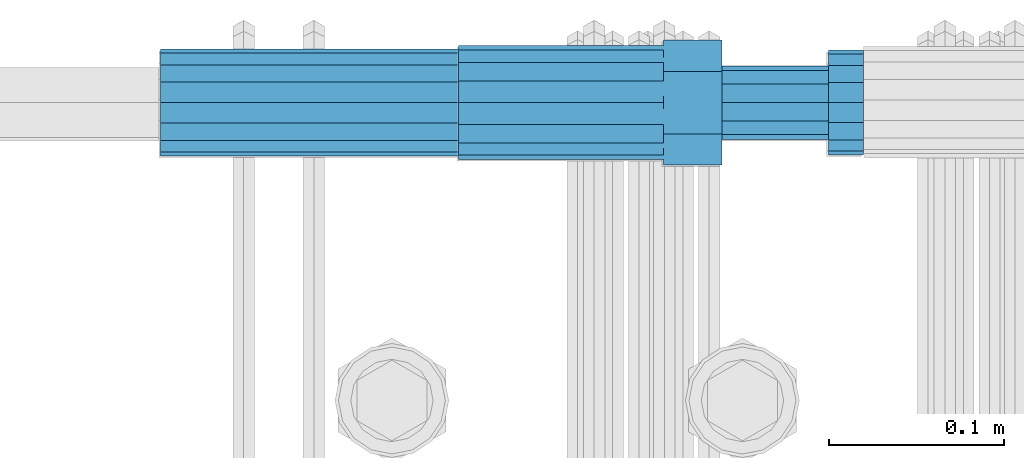
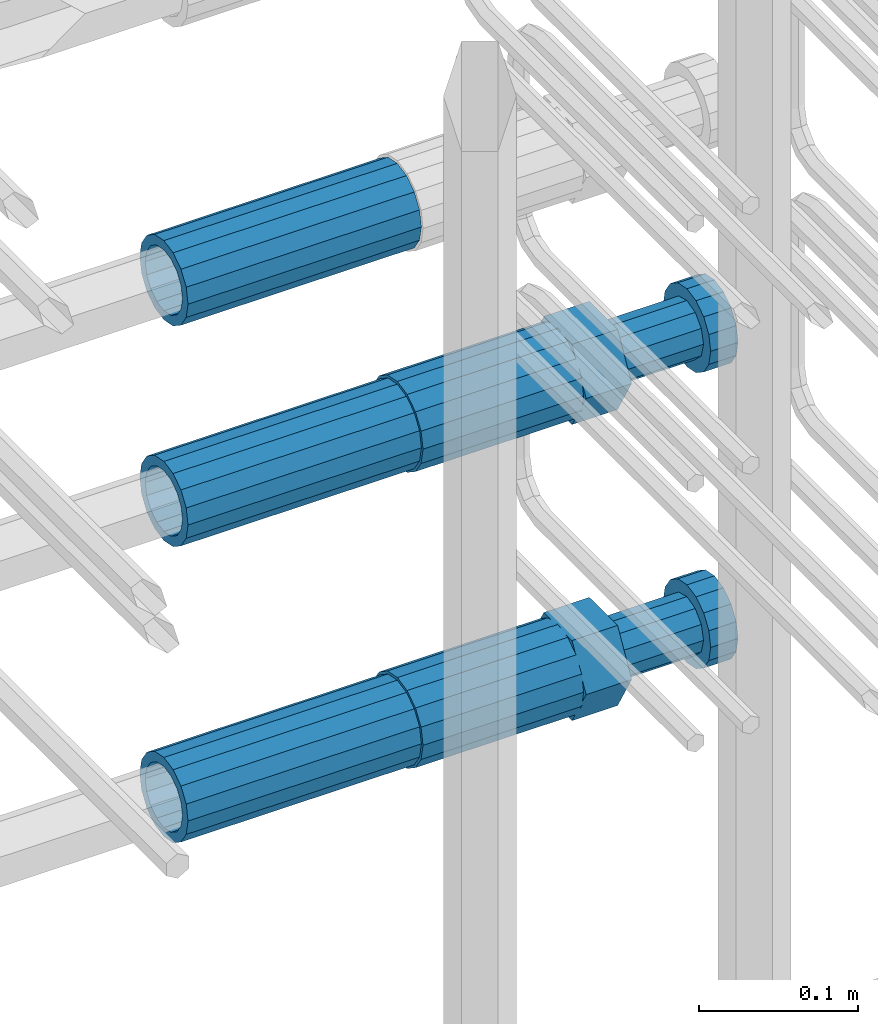
# One storey, part 51 of 177: 5 beams.
"""IFC2X3 building model written with IfcOpenShell, lengths in millimetres."""

from ifc_helpers import new_model, si_unit, frame, origin_with_axes, place, context, subcontext, project, spatial, faceted_brep, material, type_object, element, save


model = new_model("IFC2X3")

# Units and contexts
model_context_1 = context("Model", 3, precision=1e-05, world=origin_with_axes())
model_context_2 = context("Model", 3, precision=1e-05, world=origin_with_axes())
body_context = subcontext(model_context_2, "Body", "Model", "MODEL_VIEW")
ifc_project = project(units=[si_unit("LENGTHUNIT", "METRE", prefix="MILLI"), si_unit("AREAUNIT", "SQUARE_METRE"), si_unit("VOLUMEUNIT", "CUBIC_METRE"), si_unit("MASSUNIT", "GRAM", prefix="KILO"), si_unit("TIMEUNIT", "SECOND"), si_unit("PLANEANGLEUNIT", "RADIAN"), si_unit("SOLIDANGLEUNIT", "STERADIAN"), si_unit("THERMODYNAMICTEMPERATUREUNIT", "DEGREE_CELSIUS"), si_unit("LUMINOUSINTENSITYUNIT", "LUMEN")], contexts=[model_context_1])

# Site, building, storey
site_placement = place(None, origin_with_axes())
site = spatial("IfcSite", under=ifc_project, at=site_placement, CompositionType="ELEMENT")
building_placement = place(site_placement, origin_with_axes())
building = spatial("IfcBuilding", under=site, at=building_placement, Name="Undefined", CompositionType="ELEMENT")
storey_placement = place(building_placement, origin_with_axes())
storey = spatial("IfcBuildingStorey", under=building, at=storey_placement, Name="Undefined", CompositionType="ELEMENT", Elevation=0.0)

# Beams
ifc_material = material(Name="STEEL/S275")
beam_type_1 = type_object("IfcBeamType", PredefinedType="NOTDEFINED")
beam_1_placement = place(storey_placement, frame((2031449.01847313, 6206398.98588031, 20184.6868004325), z_axis=(0.0, 0.0, -1.0), x_axis=(1.0, 0.0, 0.0)))
element("IfcBeam", 1, at=beam_1_placement, inside=storey, type_object=beam_type_1, material=ifc_material, Name="AG40N", context=body_context, shape_type="Brep", body=[
    faceted_brep([(0.0, -23.5000000001164, -9.31322574615479e-10), (0.0, -21.7111690140155, 8.99306066054851), (170.0, -21.7111690140155, 8.99306066054851), (170.0, -23.5, 0.0), (0.0, -16.6170093578839, 16.6170093575493), (170.0, -16.6170093578839, 16.6170093575493), (0.0, -8.99306066057943, 21.7111690137535), (170.0, -8.99306066057943, 21.7111690137535), (0.0, 1.16415321826935e-10, 23.5), (170.0, 0.0, 23.5), (0.0, 8.99306066057943, 21.7111690137535), (170.0, 8.99306066057943, 21.7111690137535), (0.0, 16.6170093578839, 16.6170093575493), (170.0, 16.6170093578839, 16.6170093575493), (0.0, 21.7111690140155, 8.99306066054851), (170.0, 21.7111690140155, 8.99306066054851), (0.0, 23.5000000001164, -9.31322574615479e-10), (170.0, 23.5, 0.0), (0.0, 21.7111690140155, -8.99306066054851), (170.0, 21.7111690140155, -8.99306066054851), (0.0, 16.6170093578839, -16.6170093575493), (170.0, 16.6170093578839, -16.6170093575493), (0.0, 8.99306066057943, -21.7111690137535), (170.0, 8.99306066057943, -21.7111690137535), (0.0, 1.16415321826935e-10, -23.5000000009313), (170.0, 0.0, -23.5), (0.0, -8.99306066057943, -21.7111690137535), (170.0, -8.99306066057943, -21.7111690137535), (0.0, -16.6170093578839, -16.6170093575493), (170.0, -16.6170093578839, -16.6170093575493), (0.0, -21.7111690140155, -8.99306066054851), (170.0, -21.7111690140155, -8.99306066054851), (0.0, -30.5, 0.0), (0.0, -28.1783257415937, -11.6718446873128), (170.0, -28.1783257415937, -11.6718446873128), (170.0, -30.5, 0.0), (0.0, -21.5667568261888, -21.5667568258941), (170.0, -21.5667568261888, -21.5667568258941), (0.0, -11.6718446871346, -28.1783257415518), (170.0, -11.6718446871346, -28.1783257415518), (0.0, 0.0, -30.5), (170.0, 0.0, -30.5), (0.0, 11.6718446871346, -28.1783257415518), (170.0, 11.6718446871346, -28.1783257415518), (0.0, 21.5667568261888, -21.5667568258941), (170.0, 21.5667568261888, -21.5667568258941), (0.0, 28.1783257415937, -11.6718446873128), (170.0, 28.1783257415937, -11.6718446873128), (0.0, 30.5, 0.0), (170.0, 30.5, 0.0), (0.0, 28.1783257415937, 11.6718446873128), (170.0, 28.1783257415937, 11.6718446873128), (0.0, 21.5667568261888, 21.5667568258941), (170.0, 21.5667568261888, 21.5667568258941), (0.0, 11.6718446871346, 28.1783257415518), (170.0, 11.6718446871346, 28.1783257415518), (0.0, 0.0, 30.5), (170.0, 0.0, 30.5), (0.0, -11.6718446871346, 28.1783257415518), (170.0, -11.6718446871346, 28.1783257415518), (0.0, -21.5667568261888, 21.5667568258941), (170.0, -21.5667568261888, 21.5667568258941), (0.0, -28.1783257415937, 11.6718446873128), (170.0, -28.1783257415937, 11.6718446873128)], [[[0, 1, 2, 3]], [[1, 4, 5, 2]], [[4, 6, 7, 5]], [[6, 8, 9, 7]], [[8, 10, 11, 9]], [[10, 12, 13, 11]], [[12, 14, 15, 13]], [[14, 16, 17, 15]], [[16, 18, 19, 17]], [[18, 20, 21, 19]], [[20, 22, 23, 21]], [[22, 24, 25, 23]], [[24, 26, 27, 25]], [[26, 28, 29, 27]], [[28, 30, 31, 29]], [[30, 0, 3, 31]], [[32, 33, 34, 35]], [[33, 36, 37, 34]], [[36, 38, 39, 37]], [[38, 40, 41, 39]], [[40, 42, 43, 41]], [[42, 44, 45, 43]], [[44, 46, 47, 45]], [[46, 48, 49, 47]], [[48, 50, 51, 49]], [[50, 52, 53, 51]], [[52, 54, 55, 53]], [[54, 56, 57, 55]], [[56, 58, 59, 57]], [[58, 60, 61, 59]], [[60, 62, 63, 61]], [[62, 32, 35, 63]], [[37, 39, 41, 43, 45, 47, 49, 51, 53, 55, 57, 59, 61, 63, 35, 34], [5, 7, 9, 11, 13, 15, 17, 19, 21, 23, 25, 27, 29, 31, 3, 2]], [[62, 60, 58, 56, 54, 52, 50, 48, 46, 44, 42, 40, 38, 36, 33, 32], [30, 28, 26, 24, 22, 20, 18, 16, 14, 12, 10, 8, 6, 4, 1, 0]]]),
])
beam_2_placement = place(storey_placement, frame((2031449.01847313, 6206398.98588031, 19956.6868004325), z_axis=(0.0, 0.0, -1.0), x_axis=(1.0, 0.0, 0.0)))
element("IfcBeam", 2, at=beam_2_placement, inside=storey, type_object=beam_type_1, material=ifc_material, Name="AG40N", context=body_context, shape_type="Brep", body=[
    faceted_brep([(0.0, -23.5000000001164, -9.31322574615479e-10), (0.0, -21.7111690140155, 8.99306066054851), (170.0, -21.7111690140155, 8.99306066054851), (170.0, -23.5, 0.0), (0.0, -16.6170093578839, 16.6170093575493), (170.0, -16.6170093578839, 16.6170093575493), (0.0, -8.99306066057943, 21.7111690137535), (170.0, -8.99306066057943, 21.7111690137535), (0.0, 1.16415321826935e-10, 23.5), (170.0, 0.0, 23.5), (0.0, 8.99306066057943, 21.7111690137535), (170.0, 8.99306066057943, 21.7111690137535), (0.0, 16.6170093578839, 16.6170093575493), (170.0, 16.6170093578839, 16.6170093575493), (0.0, 21.7111690140155, 8.99306066054851), (170.0, 21.7111690140155, 8.99306066054851), (0.0, 23.5000000001164, -9.31322574615479e-10), (170.0, 23.5, 0.0), (0.0, 21.7111690140155, -8.99306066054851), (170.0, 21.7111690140155, -8.99306066054851), (0.0, 16.6170093578839, -16.6170093575493), (170.0, 16.6170093578839, -16.6170093575493), (0.0, 8.99306066057943, -21.7111690137535), (170.0, 8.99306066057943, -21.7111690137535), (0.0, 1.16415321826935e-10, -23.5000000009313), (170.0, 0.0, -23.5), (0.0, -8.99306066057943, -21.7111690137535), (170.0, -8.99306066057943, -21.7111690137535), (0.0, -16.6170093578839, -16.6170093575493), (170.0, -16.6170093578839, -16.6170093575493), (0.0, -21.7111690140155, -8.99306066054851), (170.0, -21.7111690140155, -8.99306066054851), (0.0, -30.5, 0.0), (0.0, -28.1783257415937, -11.6718446873128), (170.0, -28.1783257415937, -11.6718446873128), (170.0, -30.5, 0.0), (0.0, -21.5667568261888, -21.5667568258941), (170.0, -21.5667568261888, -21.5667568258941), (0.0, -11.6718446871346, -28.1783257415518), (170.0, -11.6718446871346, -28.1783257415518), (0.0, 0.0, -30.5), (170.0, 0.0, -30.5), (0.0, 11.6718446871346, -28.1783257415518), (170.0, 11.6718446871346, -28.1783257415518), (0.0, 21.5667568261888, -21.5667568258941), (170.0, 21.5667568261888, -21.5667568258941), (0.0, 28.1783257415937, -11.6718446873128), (170.0, 28.1783257415937, -11.6718446873128), (0.0, 30.5, 0.0), (170.0, 30.5, 0.0), (0.0, 28.1783257415937, 11.6718446873128), (170.0, 28.1783257415937, 11.6718446873128), (0.0, 21.5667568261888, 21.5667568258941), (170.0, 21.5667568261888, 21.5667568258941), (0.0, 11.6718446871346, 28.1783257415518), (170.0, 11.6718446871346, 28.1783257415518), (0.0, 0.0, 30.5), (170.0, 0.0, 30.5), (0.0, -11.6718446871346, 28.1783257415518), (170.0, -11.6718446871346, 28.1783257415518), (0.0, -21.5667568261888, 21.5667568258941), (170.0, -21.5667568261888, 21.5667568258941), (0.0, -28.1783257415937, 11.6718446873128), (170.0, -28.1783257415937, 11.6718446873128)], [[[0, 1, 2, 3]], [[1, 4, 5, 2]], [[4, 6, 7, 5]], [[6, 8, 9, 7]], [[8, 10, 11, 9]], [[10, 12, 13, 11]], [[12, 14, 15, 13]], [[14, 16, 17, 15]], [[16, 18, 19, 17]], [[18, 20, 21, 19]], [[20, 22, 23, 21]], [[22, 24, 25, 23]], [[24, 26, 27, 25]], [[26, 28, 29, 27]], [[28, 30, 31, 29]], [[30, 0, 3, 31]], [[32, 33, 34, 35]], [[33, 36, 37, 34]], [[36, 38, 39, 37]], [[38, 40, 41, 39]], [[40, 42, 43, 41]], [[42, 44, 45, 43]], [[44, 46, 47, 45]], [[46, 48, 49, 47]], [[48, 50, 51, 49]], [[50, 52, 53, 51]], [[52, 54, 55, 53]], [[54, 56, 57, 55]], [[56, 58, 59, 57]], [[58, 60, 61, 59]], [[60, 62, 63, 61]], [[62, 32, 35, 63]], [[37, 39, 41, 43, 45, 47, 49, 51, 53, 55, 57, 59, 61, 63, 35, 34], [5, 7, 9, 11, 13, 15, 17, 19, 21, 23, 25, 27, 29, 31, 3, 2]], [[62, 60, 58, 56, 54, 52, 50, 48, 46, 44, 42, 40, 38, 36, 33, 32], [30, 28, 26, 24, 22, 20, 18, 16, 14, 12, 10, 8, 6, 4, 1, 0]]]),
])
beam_3_placement = place(storey_placement, frame((2031449.01847313, 6206398.98588031, 20354.6868004329), z_axis=(0.0, 0.0, -1.0), x_axis=(1.0, 0.0, 0.0)))
element("IfcBeam", 3, at=beam_3_placement, inside=storey, type_object=beam_type_1, material=ifc_material, Name="AG40N", context=body_context, shape_type="Brep", body=[
    faceted_brep([(0.0, -23.5000000001164, -9.31322574615479e-10), (0.0, -21.7111690140155, 8.99306066054851), (170.0, -21.7111690140155, 8.99306066054851), (170.0, -23.5, 0.0), (0.0, -16.6170093578839, 16.6170093575493), (170.0, -16.6170093578839, 16.6170093575493), (0.0, -8.99306066057943, 21.7111690137535), (170.0, -8.99306066057943, 21.7111690137535), (0.0, 1.16415321826935e-10, 23.5), (170.0, 0.0, 23.5), (0.0, 8.99306066057943, 21.7111690137535), (170.0, 8.99306066057943, 21.7111690137535), (0.0, 16.6170093578839, 16.6170093575493), (170.0, 16.6170093578839, 16.6170093575493), (0.0, 21.7111690140155, 8.99306066054851), (170.0, 21.7111690140155, 8.99306066054851), (0.0, 23.5000000001164, -9.31322574615479e-10), (170.0, 23.5, 0.0), (0.0, 21.7111690140155, -8.99306066054851), (170.0, 21.7111690140155, -8.99306066054851), (0.0, 16.6170093578839, -16.6170093575493), (170.0, 16.6170093578839, -16.6170093575493), (0.0, 8.99306066057943, -21.7111690137535), (170.0, 8.99306066057943, -21.7111690137535), (0.0, 1.16415321826935e-10, -23.5000000009313), (170.0, 0.0, -23.5), (0.0, -8.99306066057943, -21.7111690137535), (170.0, -8.99306066057943, -21.7111690137535), (0.0, -16.6170093578839, -16.6170093575493), (170.0, -16.6170093578839, -16.6170093575493), (0.0, -21.7111690140155, -8.99306066054851), (170.0, -21.7111690140155, -8.99306066054851), (0.0, -30.5, 0.0), (0.0, -28.1783257415937, -11.6718446873128), (170.0, -28.1783257415937, -11.6718446873128), (170.0, -30.5, 0.0), (0.0, -21.5667568261888, -21.5667568258941), (170.0, -21.5667568261888, -21.5667568258941), (0.0, -11.6718446871346, -28.1783257415518), (170.0, -11.6718446871346, -28.1783257415518), (0.0, 0.0, -30.5), (170.0, 0.0, -30.5), (0.0, 11.6718446871346, -28.1783257415518), (170.0, 11.6718446871346, -28.1783257415518), (0.0, 21.5667568261888, -21.5667568258941), (170.0, 21.5667568261888, -21.5667568258941), (0.0, 28.1783257415937, -11.6718446873128), (170.0, 28.1783257415937, -11.6718446873128), (0.0, 30.5, 0.0), (170.0, 30.5, 0.0), (0.0, 28.1783257415937, 11.6718446873128), (170.0, 28.1783257415937, 11.6718446873128), (0.0, 21.5667568261888, 21.5667568258941), (170.0, 21.5667568261888, 21.5667568258941), (0.0, 11.6718446871346, 28.1783257415518), (170.0, 11.6718446871346, 28.1783257415518), (0.0, 0.0, 30.5), (170.0, 0.0, 30.5), (0.0, -11.6718446871346, 28.1783257415518), (170.0, -11.6718446871346, 28.1783257415518), (0.0, -21.5667568261888, 21.5667568258941), (170.0, -21.5667568261888, 21.5667568258941), (0.0, -28.1783257415937, 11.6718446873128), (170.0, -28.1783257415937, 11.6718446873128)], [[[0, 1, 2, 3]], [[1, 4, 5, 2]], [[4, 6, 7, 5]], [[6, 8, 9, 7]], [[8, 10, 11, 9]], [[10, 12, 13, 11]], [[12, 14, 15, 13]], [[14, 16, 17, 15]], [[16, 18, 19, 17]], [[18, 20, 21, 19]], [[20, 22, 23, 21]], [[22, 24, 25, 23]], [[24, 26, 27, 25]], [[26, 28, 29, 27]], [[28, 30, 31, 29]], [[30, 0, 3, 31]], [[32, 33, 34, 35]], [[33, 36, 37, 34]], [[36, 38, 39, 37]], [[38, 40, 41, 39]], [[40, 42, 43, 41]], [[42, 44, 45, 43]], [[44, 46, 47, 45]], [[46, 48, 49, 47]], [[48, 50, 51, 49]], [[50, 52, 53, 51]], [[52, 54, 55, 53]], [[54, 56, 57, 55]], [[56, 58, 59, 57]], [[58, 60, 61, 59]], [[60, 62, 63, 61]], [[62, 32, 35, 63]], [[37, 39, 41, 43, 45, 47, 49, 51, 53, 55, 57, 59, 61, 63, 35, 34], [5, 7, 9, 11, 13, 15, 17, 19, 21, 23, 25, 27, 29, 31, 3, 2]], [[62, 60, 58, 56, 54, 52, 50, 48, 46, 44, 42, 40, 38, 36, 33, 32], [30, 28, 26, 24, 22, 20, 18, 16, 14, 12, 10, 8, 6, 4, 1, 0]]]),
])
beam_type_2 = type_object("IfcBeamType", Name="ROD65", PredefinedType="NOTDEFINED")
beam_4_placement = place(storey_placement, frame((2031619.01847313, 6206398.98588031, 20184.6868004325), z_axis=(0.0, 0.0, -1.0), x_axis=(1.0, 0.0, 0.0)))
element("IfcBeam", 4, at=beam_4_placement, inside=storey, type_object=beam_type_2, material=ifc_material, Name="AGB40", ObjectType="ROD65", context=body_context, shape_type="Brep", body=[
    faceted_brep([(117.0, 8.17543110251427, 30.873805644922), (117.0, 17.8250000001863, 30.873805644922), (117.0, 22.0056958701462, 23.6326279877685), (117.0, 12.4372115517035, 30.0260848065373), (117.0, -17.8250000001863, 30.873805644922), (150.200000000186, -17.8250000001863, 30.873805644922), (150.200000000186, 17.8250000001863, 30.873805644922), (117.0, -8.17543110251427, 30.873805644922), (117.0, -12.4372115517035, 30.0260848065373), (117.0, -22.0056958701462, 23.6326279877685), (117.0, -35.6500000003725, 0.0), (150.200000000186, -35.6500000003725, 0.0), (117.0, -30.8443150008097, 8.32369058486074), (117.0, -32.5, 0.0), (117.0, -30.8443150008097, -8.32369058462791), (117.0, -17.8250000001863, -30.873805644922), (150.200000000186, -17.8250000001863, -30.873805644922), (117.0, -22.0056958701462, -23.6326279877685), (117.0, -12.4372115517035, -30.0260848065373), (117.0, -8.17543110251427, -30.873805644922), (117.0, 17.8250000001863, -30.873805644922), (150.200000000186, 17.8250000001863, -30.873805644922), (117.0, 8.17543110251427, -30.873805644922), (117.0, 22.0056958701462, -23.6326279877685), (117.0, 12.4372115517035, -30.0260848065373), (117.0, 35.6500000003725, 0.0), (150.200000000186, 35.6500000003725, 0.0), (117.0, 30.8443150008097, -8.32369058486074), (117.0, 30.8443150008097, 8.32369058462791), (117.0, 32.5, 0.0), (0.0, -22.9809703892097, 22.9809703885621), (0.0, -30.0260848058388, 12.4372115518636), (117.0, -30.0260848067701, 12.4372115519363), (117.0, -22.9809703882784, 22.9809703885112), (-2.3283064365387e-10, 22.9809703892097, -22.9809703885639), (-4.65661287307739e-10, 30.0260848077014, -12.4372115518672), (117.0, 30.0260848067701, -12.4372115519363), (117.0, 22.9809703882784, -22.9809703885112), (-2.3283064365387e-10, -30.0260848067701, -12.4372115518672), (-2.3283064365387e-10, -22.9809703892097, -22.9809703885621), (117.0, -22.9809703882784, -22.9809703885112), (117.0, -30.0260848067701, -12.4372115519363), (-2.3283064365387e-10, -12.4372115507722, 30.0260848066137), (-2.3283064365387e-10, 9.31322574615479e-10, 32.4999999999982), (-2.3283064365387e-10, 12.4372115526348, 30.0260848066137), (0.0, 22.9809703892097, 22.9809703885621), (-2.3283064365387e-10, 30.0260848077014, 12.4372115518636), (-2.3283064365387e-10, 32.5, 0.0), (-2.3283064365387e-10, 12.4372115526348, -30.0260848066173), (-2.3283064365387e-10, 9.31322574615479e-10, -32.5), (-2.3283064365387e-10, -12.4372115517035, -30.0260848066173), (-4.65661287307739e-10, -32.4999999990687, -1.81898940354586e-12), (117.0, 22.9809703882784, 22.9809703885112), (117.0, 30.0260848067701, 12.4372115519363), (117.0, 0.0, -32.5), (117.0, 0.0, 32.5), (150.200000000186, 10.5, -18.1865334794857), (150.200000000186, 0.0, -21.0), (150.200000000186, -10.5, -18.1865334794857), (150.200000000186, -18.18653347902, -10.5), (150.200000000186, -21.0, 0.0), (150.200000000186, -18.18653347902, 10.5), (150.200000000186, -10.5, 18.1865334794857), (150.200000000186, 0.0, 21.0), (150.200000000186, 10.5, 18.1865334794857), (150.200000000186, 18.18653347902, 10.5), (150.200000000186, 21.0, 0.0), (150.200000000186, 18.18653347902, -10.5), (210.980000000447, -18.18653347902, 10.5), (210.980000000447, -21.0, 0.0), (210.980000000447, -10.5, 18.1865334794857), (210.980000000447, 0.0, 21.0), (210.980000000447, 10.5, 18.1865334794857), (210.980000000447, 18.18653347902, 10.5), (210.980000000447, 21.0, 0.0), (210.980000000447, 18.18653347902, -10.5), (210.980000000447, 10.5, -18.1865334794857), (210.980000000447, 0.0, -21.0), (210.980000000447, -10.5, -18.1865334794857), (210.980000000447, -18.18653347902, -10.5), (211.001368442696, -27.7269937992096, -11.491116326768), (211.003082550167, -21.2238094303757, -21.223815418547), (231.002518367059, -21.2131944671273, -21.2132004550658), (231.000804259587, -27.7163788359612, -11.4805013632867), (211.001368440451, -11.4911085031927, -27.7269970395137), (231.000804257343, -11.4804935399443, -27.7163820760325), (210.996487071217, -0.0106065049767494, -30.0106107392348), (230.995922888109, 8.45827162265778e-06, -29.9999957757536), (210.989181586672, 11.46989420522, -27.7269970329944), (230.988617403564, 11.4805091684684, -27.7163820695132), (210.980564180623, 21.2025914648548, -21.2238154064398), (230.979999997515, 21.2132064281031, -21.2132004429586), (210.971946775022, 27.7057703435421, -11.4911163107026), (230.971382591913, 27.7163853067905, -11.4805013472214), (210.96464129175, 29.9893808094785, -0.0106149562634528), (230.964077108642, 29.9999957727268, 7.21774995326996e-09), (210.959759924415, 27.7057638689876, 11.4698863970116), (230.959195741307, 27.7163788322359, 11.4805013604928), (210.958045816944, 21.2025795001537, 21.2025854887906), (230.957481633835, 21.213194463402, 21.2132004522718), (210.95975992666, 11.4698785729706, 27.7057671097573), (230.959195743551, 11.480493536219, 27.7163820732385), (210.964641295894, -0.010623425245285, 29.9893808094785), (230.964077112785, -8.46199691295624e-06, 29.9999957729597), (210.971946780439, -11.4911241354421, 27.705767103238), (230.97138259733, -11.4805091721937, 27.7163820667192), (210.980564186488, -21.2238213950768, 21.2025854766835), (230.980000003379, -21.2132064318284, 21.2132004401647), (210.989181592089, -27.7270002737641, 11.4698863809463), (230.988617408981, -27.7163853105158, 11.4805013444275), (210.996487075361, -30.0106107397005, -0.0106149734929204), (230.995922892253, -29.9999957764521, -1.00117176771164e-08)], [[[0, 1, 2, 3]], [[4, 5, 6, 1, 0, 7]], [[4, 7, 8, 9]], [[10, 11, 5, 4, 9, 12]], [[10, 12, 13, 14]], [[15, 16, 11, 10, 14, 17]], [[15, 17, 18, 19]], [[20, 21, 16, 15, 19, 22]], [[23, 20, 22, 24]], [[25, 26, 21, 20, 23, 27]], [[28, 25, 27, 29]], [[30, 31, 32, 33]], [[34, 35, 36, 37]], [[38, 39, 40, 41]], [[31, 30, 42, 43, 44, 45, 46, 47, 35, 34, 48, 49, 50, 39, 38, 51]], [[46, 45, 52, 53]], [[29, 47, 46, 53, 28]], [[27, 36, 35, 47, 29]], [[23, 37, 36, 27]], [[24, 48, 34, 37, 23]], [[22, 54, 49, 48, 24]], [[19, 54, 22]], [[18, 50, 49, 54, 19]], [[17, 40, 39, 50, 18]], [[14, 41, 40, 17]], [[13, 51, 38, 41, 14]], [[12, 32, 31, 51, 13]], [[9, 33, 32, 12]], [[8, 42, 30, 33, 9]], [[7, 55, 43, 42, 8]], [[0, 55, 7]], [[3, 44, 43, 55, 0]], [[2, 52, 45, 44, 3]], [[28, 53, 52, 2]], [[1, 6, 26, 25, 28, 2]], [[5, 11, 16, 21, 26, 6], [56, 57, 58, 59, 60, 61, 62, 63, 64, 65, 66, 67]], [[68, 61, 60, 69]], [[70, 62, 61, 68]], [[71, 63, 62, 70]], [[72, 64, 63, 71]], [[73, 65, 64, 72]], [[74, 66, 65, 73]], [[75, 67, 66, 74]], [[76, 56, 67, 75]], [[77, 57, 56, 76]], [[78, 58, 57, 77]], [[79, 59, 58, 78]], [[69, 60, 59, 79]], [[80, 81, 82, 83]], [[81, 84, 85, 82]], [[84, 86, 87, 85]], [[86, 88, 89, 87]], [[88, 90, 91, 89]], [[90, 92, 93, 91]], [[92, 94, 95, 93]], [[94, 96, 97, 95]], [[96, 98, 99, 97]], [[98, 100, 101, 99]], [[100, 102, 103, 101]], [[102, 104, 105, 103]], [[104, 106, 107, 105]], [[106, 108, 109, 107]], [[108, 110, 111, 109]], [[82, 85, 87, 89, 91, 93, 95, 97, 99, 101, 103, 105, 107, 109, 111, 83]], [[110, 80, 83, 111]], [[108, 106, 104, 102, 100, 98, 96, 94, 92, 90, 88, 86, 84, 81, 80, 110], [75, 74, 73, 72, 71, 70, 68, 69, 79, 78, 77, 76]]]),
])
beam_5_placement = place(storey_placement, frame((2031619.01847313, 6206398.98588031, 19956.6868004325), z_axis=(0.0, 0.0, -1.0), x_axis=(1.0, 0.0, 0.0)))
element("IfcBeam", 5, at=beam_5_placement, inside=storey, type_object=beam_type_2, material=ifc_material, Name="AGB40", ObjectType="ROD65", context=body_context, shape_type="Brep", body=[
    faceted_brep([(117.0, 8.17543110251427, 30.873805644922), (117.0, 17.8250000001863, 30.873805644922), (117.0, 22.0056958701462, 23.6326279877685), (117.0, 12.4372115517035, 30.0260848065373), (117.0, -17.8250000001863, 30.873805644922), (150.200000000186, -17.8250000001863, 30.873805644922), (150.200000000186, 17.8250000001863, 30.873805644922), (117.0, -8.17543110251427, 30.873805644922), (117.0, -12.4372115517035, 30.0260848065373), (117.0, -22.0056958701462, 23.6326279877685), (117.0, -35.6500000003725, 0.0), (150.200000000186, -35.6500000003725, 0.0), (117.0, -30.8443150008097, 8.32369058486074), (117.0, -32.5, 0.0), (117.0, -30.8443150008097, -8.32369058462791), (117.0, -17.8250000001863, -30.873805644922), (150.200000000186, -17.8250000001863, -30.873805644922), (117.0, -22.0056958701462, -23.6326279877685), (117.0, -12.4372115517035, -30.0260848065373), (117.0, -8.17543110251427, -30.873805644922), (117.0, 17.8250000001863, -30.873805644922), (150.200000000186, 17.8250000001863, -30.873805644922), (117.0, 8.17543110251427, -30.873805644922), (117.0, 22.0056958701462, -23.6326279877685), (117.0, 12.4372115517035, -30.0260848065373), (117.0, 35.6500000003725, 0.0), (150.200000000186, 35.6500000003725, 0.0), (117.0, 30.8443150008097, -8.32369058486074), (117.0, 30.8443150008097, 8.32369058462791), (117.0, 32.5, 0.0), (0.0, -22.9809703892097, 22.9809703885621), (0.0, -30.0260848058388, 12.4372115518636), (117.0, -30.0260848067701, 12.4372115519363), (117.0, -22.9809703882784, 22.9809703885112), (-2.3283064365387e-10, 22.9809703892097, -22.9809703885639), (-4.65661287307739e-10, 30.0260848077014, -12.4372115518672), (117.0, 30.0260848067701, -12.4372115519363), (117.0, 22.9809703882784, -22.9809703885112), (-2.3283064365387e-10, -30.0260848067701, -12.4372115518672), (-2.3283064365387e-10, -22.9809703892097, -22.9809703885621), (117.0, -22.9809703882784, -22.9809703885112), (117.0, -30.0260848067701, -12.4372115519363), (-2.3283064365387e-10, -12.4372115507722, 30.0260848066137), (-2.3283064365387e-10, 9.31322574615479e-10, 32.4999999999982), (-2.3283064365387e-10, 12.4372115526348, 30.0260848066137), (0.0, 22.9809703892097, 22.9809703885621), (-2.3283064365387e-10, 30.0260848077014, 12.4372115518636), (-2.3283064365387e-10, 32.5, 0.0), (-2.3283064365387e-10, 12.4372115526348, -30.0260848066173), (-2.3283064365387e-10, 9.31322574615479e-10, -32.5), (-2.3283064365387e-10, -12.4372115517035, -30.0260848066173), (-4.65661287307739e-10, -32.4999999990687, -1.81898940354586e-12), (117.0, 22.9809703882784, 22.9809703885112), (117.0, 30.0260848067701, 12.4372115519363), (117.0, 0.0, -32.5), (117.0, 0.0, 32.5), (150.200000000186, 10.5, -18.1865334794857), (150.200000000186, 0.0, -21.0), (150.200000000186, -10.5, -18.1865334794857), (150.200000000186, -18.18653347902, -10.5), (150.200000000186, -21.0, 0.0), (150.200000000186, -18.18653347902, 10.5), (150.200000000186, -10.5, 18.1865334794857), (150.200000000186, 0.0, 21.0), (150.200000000186, 10.5, 18.1865334794857), (150.200000000186, 18.18653347902, 10.5), (150.200000000186, 21.0, 0.0), (150.200000000186, 18.18653347902, -10.5), (210.980000000447, -18.18653347902, 10.5), (210.980000000447, -21.0, 0.0), (210.980000000447, -10.5, 18.1865334794857), (210.980000000447, 0.0, 21.0), (210.980000000447, 10.5, 18.1865334794857), (210.980000000447, 18.18653347902, 10.5), (210.980000000447, 21.0, 0.0), (210.980000000447, 18.18653347902, -10.5), (210.980000000447, 10.5, -18.1865334794857), (210.980000000447, 0.0, -21.0), (210.980000000447, -10.5, -18.1865334794857), (210.980000000447, -18.18653347902, -10.5), (211.001368442696, -27.7269937992096, -11.491116326768), (211.003082550167, -21.2238094303757, -21.223815418547), (231.002518367059, -21.2131944671273, -21.2132004550658), (231.000804259587, -27.7163788359612, -11.4805013632867), (211.001368440451, -11.4911085031927, -27.7269970395137), (231.000804257343, -11.4804935399443, -27.7163820760325), (210.996487071217, -0.0106065049767494, -30.0106107392348), (230.995922888109, 8.45827162265778e-06, -29.9999957757536), (210.989181586672, 11.46989420522, -27.7269970329944), (230.988617403564, 11.4805091684684, -27.7163820695132), (210.980564180623, 21.2025914648548, -21.2238154064398), (230.979999997515, 21.2132064281031, -21.2132004429586), (210.971946775022, 27.7057703435421, -11.4911163107026), (230.971382591913, 27.7163853067905, -11.4805013472214), (210.96464129175, 29.9893808094785, -0.0106149562634528), (230.964077108642, 29.9999957727268, 7.21774995326996e-09), (210.959759924415, 27.7057638689876, 11.4698863970116), (230.959195741307, 27.7163788322359, 11.4805013604928), (210.958045816944, 21.2025795001537, 21.2025854887906), (230.957481633835, 21.213194463402, 21.2132004522718), (210.95975992666, 11.4698785729706, 27.7057671097573), (230.959195743551, 11.480493536219, 27.7163820732385), (210.964641295894, -0.010623425245285, 29.9893808094785), (230.964077112785, -8.46199691295624e-06, 29.9999957729597), (210.971946780439, -11.4911241354421, 27.705767103238), (230.97138259733, -11.4805091721937, 27.7163820667192), (210.980564186488, -21.2238213950768, 21.2025854766835), (230.980000003379, -21.2132064318284, 21.2132004401647), (210.989181592089, -27.7270002737641, 11.4698863809463), (230.988617408981, -27.7163853105158, 11.4805013444275), (210.996487075361, -30.0106107397005, -0.0106149734929204), (230.995922892253, -29.9999957764521, -1.00117176771164e-08)], [[[0, 1, 2, 3]], [[4, 5, 6, 1, 0, 7]], [[4, 7, 8, 9]], [[10, 11, 5, 4, 9, 12]], [[10, 12, 13, 14]], [[15, 16, 11, 10, 14, 17]], [[15, 17, 18, 19]], [[20, 21, 16, 15, 19, 22]], [[23, 20, 22, 24]], [[25, 26, 21, 20, 23, 27]], [[28, 25, 27, 29]], [[30, 31, 32, 33]], [[34, 35, 36, 37]], [[38, 39, 40, 41]], [[31, 30, 42, 43, 44, 45, 46, 47, 35, 34, 48, 49, 50, 39, 38, 51]], [[46, 45, 52, 53]], [[29, 47, 46, 53, 28]], [[27, 36, 35, 47, 29]], [[23, 37, 36, 27]], [[24, 48, 34, 37, 23]], [[22, 54, 49, 48, 24]], [[19, 54, 22]], [[18, 50, 49, 54, 19]], [[17, 40, 39, 50, 18]], [[14, 41, 40, 17]], [[13, 51, 38, 41, 14]], [[12, 32, 31, 51, 13]], [[9, 33, 32, 12]], [[8, 42, 30, 33, 9]], [[7, 55, 43, 42, 8]], [[0, 55, 7]], [[3, 44, 43, 55, 0]], [[2, 52, 45, 44, 3]], [[28, 53, 52, 2]], [[1, 6, 26, 25, 28, 2]], [[5, 11, 16, 21, 26, 6], [56, 57, 58, 59, 60, 61, 62, 63, 64, 65, 66, 67]], [[68, 61, 60, 69]], [[70, 62, 61, 68]], [[71, 63, 62, 70]], [[72, 64, 63, 71]], [[73, 65, 64, 72]], [[74, 66, 65, 73]], [[75, 67, 66, 74]], [[76, 56, 67, 75]], [[77, 57, 56, 76]], [[78, 58, 57, 77]], [[79, 59, 58, 78]], [[69, 60, 59, 79]], [[80, 81, 82, 83]], [[81, 84, 85, 82]], [[84, 86, 87, 85]], [[86, 88, 89, 87]], [[88, 90, 91, 89]], [[90, 92, 93, 91]], [[92, 94, 95, 93]], [[94, 96, 97, 95]], [[96, 98, 99, 97]], [[98, 100, 101, 99]], [[100, 102, 103, 101]], [[102, 104, 105, 103]], [[104, 106, 107, 105]], [[106, 108, 109, 107]], [[108, 110, 111, 109]], [[82, 85, 87, 89, 91, 93, 95, 97, 99, 101, 103, 105, 107, 109, 111, 83]], [[110, 80, 83, 111]], [[108, 106, 104, 102, 100, 98, 96, 94, 92, 90, 88, 86, 84, 81, 80, 110], [75, 74, 73, 72, 71, 70, 68, 69, 79, 78, 77, 76]]]),
])

save(model, "model.ifc")
